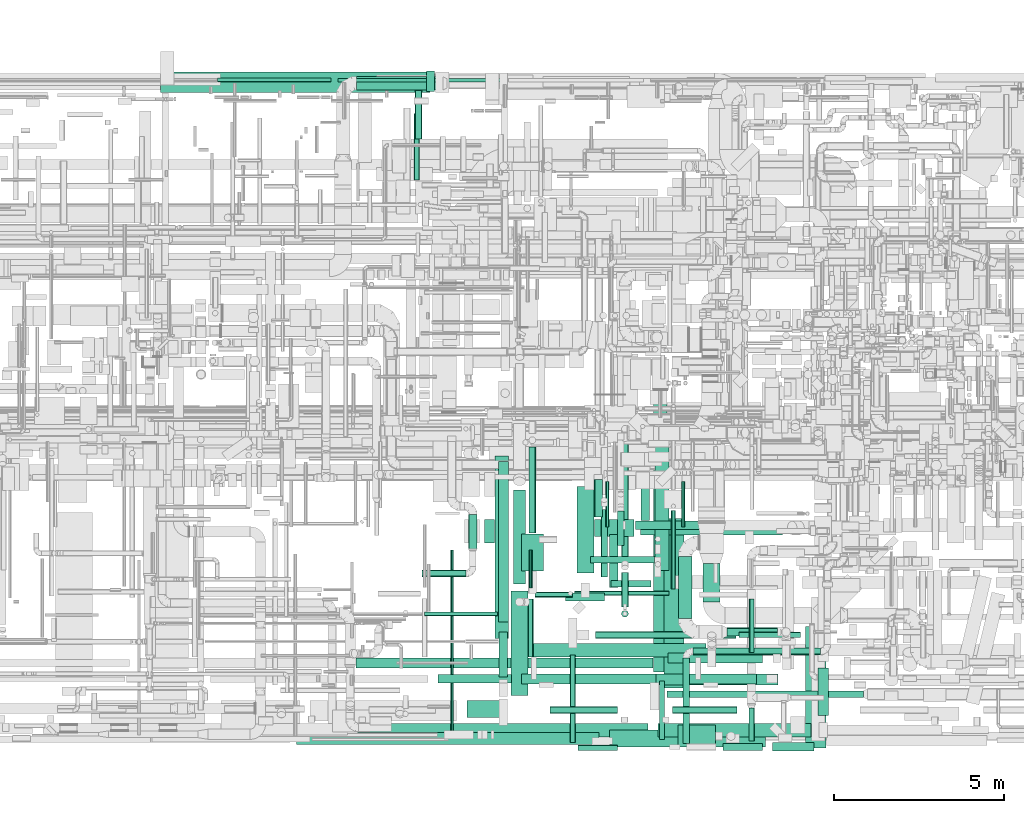
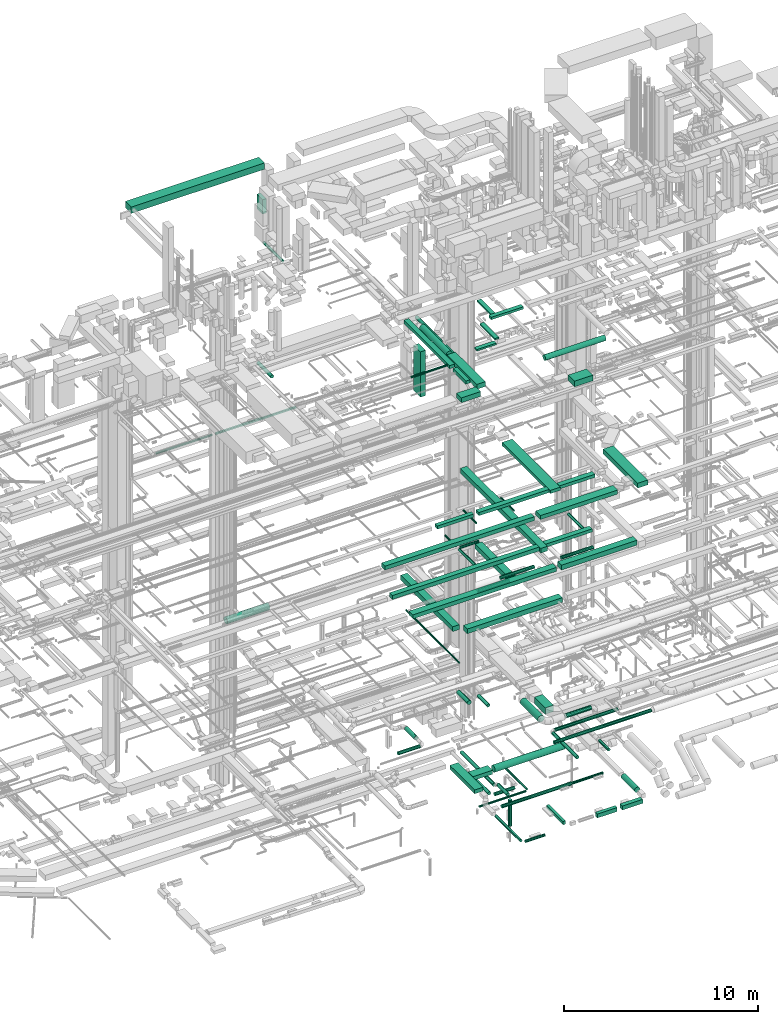
# One storey, part 37 of 337: 76 flow segments.
"""IFC2X3 building model written with IfcOpenShell, lengths in millimetres."""

from ifc_helpers import new_model, entity, si_unit, converted_unit, derived_unit, direction, frame, origin, origin_2d_with_axis, place, context, subcontext, project, spatial, rectangle, circle, extrude, type_object, element, save


model = new_model("IFC2X3")

# Units and contexts
model_context = context("Model", 3, precision=0.01, world=origin(), true_north=direction((6.12303176911189e-17, 1.0)))
body_context = subcontext(model_context, "Body", "Model", "MODEL_VIEW")
ifc_project = project(units=[si_unit("LENGTHUNIT", "METRE", prefix="MILLI"), si_unit("AREAUNIT", "SQUARE_METRE"), si_unit("VOLUMEUNIT", "CUBIC_METRE"), converted_unit("PLANEANGLEUNIT", "DEGREE", entity("IfcRatioMeasure", 0.0174532925199433), si_unit("PLANEANGLEUNIT", "RADIAN"), dimensions=[0, 0, 0, 0, 0, 0, 0]), si_unit("MASSUNIT", "GRAM", prefix="KILO"), derived_unit("MASSDENSITYUNIT", [(si_unit("MASSUNIT", "GRAM", prefix="KILO"), 1), (si_unit("LENGTHUNIT", "METRE"), -3)]), derived_unit("MOMENTOFINERTIAUNIT", [(si_unit("LENGTHUNIT", "METRE"), 4)]), si_unit("TIMEUNIT", "SECOND"), si_unit("FREQUENCYUNIT", "HERTZ"), si_unit("THERMODYNAMICTEMPERATUREUNIT", "DEGREE_CELSIUS"), derived_unit("THERMALTRANSMITTANCEUNIT", [(si_unit("MASSUNIT", "GRAM", prefix="KILO"), 1), (si_unit("THERMODYNAMICTEMPERATUREUNIT", "KELVIN"), -1), (si_unit("TIMEUNIT", "SECOND"), -3)]), derived_unit("VOLUMETRICFLOWRATEUNIT", [(si_unit("LENGTHUNIT", "METRE"), 3), (si_unit("TIMEUNIT", "SECOND"), -1)]), derived_unit("MASSFLOWRATEUNIT", [(si_unit("MASSUNIT", "GRAM", prefix="KILO"), 1), (si_unit("TIMEUNIT", "SECOND"), -1)]), derived_unit("ROTATIONALFREQUENCYUNIT", [(si_unit("TIMEUNIT", "SECOND"), -1)]), si_unit("ELECTRICCURRENTUNIT", "AMPERE"), si_unit("ELECTRICVOLTAGEUNIT", "VOLT"), si_unit("POWERUNIT", "WATT"), si_unit("FORCEUNIT", "NEWTON", prefix="KILO"), si_unit("ILLUMINANCEUNIT", "LUX"), si_unit("LUMINOUSFLUXUNIT", "LUMEN"), si_unit("LUMINOUSINTENSITYUNIT", "CANDELA"), derived_unit("USERDEFINED", [(si_unit("MASSUNIT", "GRAM", prefix="KILO"), -1), (si_unit("LENGTHUNIT", "METRE"), -2), (si_unit("TIMEUNIT", "SECOND"), 3), (si_unit("LUMINOUSFLUXUNIT", "LUMEN"), 1)]), derived_unit("LINEARVELOCITYUNIT", [(si_unit("LENGTHUNIT", "METRE"), 1), (si_unit("TIMEUNIT", "SECOND"), -1)]), si_unit("PRESSUREUNIT", "PASCAL"), derived_unit("USERDEFINED", [(si_unit("LENGTHUNIT", "METRE"), -2), (si_unit("MASSUNIT", "GRAM", prefix="KILO"), 1), (si_unit("TIMEUNIT", "SECOND"), -2)]), derived_unit("LINEARFORCEUNIT", [(si_unit("MASSUNIT", "GRAM", prefix="KILO"), 1), (si_unit("LENGTHUNIT", "METRE"), 1), (si_unit("TIMEUNIT", "SECOND"), -2), (si_unit("LENGTHUNIT", "METRE"), -1)]), derived_unit("PLANARFORCEUNIT", [(si_unit("MASSUNIT", "GRAM", prefix="KILO"), 1), (si_unit("LENGTHUNIT", "METRE"), 1), (si_unit("TIMEUNIT", "SECOND"), -2), (si_unit("LENGTHUNIT", "METRE"), -2)])], contexts=[model_context])

# Site, building, storey
site_placement = place(None, origin())
site = spatial("IfcSite", under=ifc_project, at=site_placement, CompositionType="ELEMENT")
building_placement = place(site_placement, origin())
building = spatial("IfcBuilding", under=site, at=building_placement, CompositionType="ELEMENT")
storey_placement = place(building_placement, origin())
storey = spatial("IfcBuildingStorey", under=building, at=storey_placement, CompositionType="ELEMENT", Elevation=0.0)

# Flow segments
duct_segment_type_1 = type_object("IfcDuctSegmentType", PredefinedType="NOTDEFINED")
flow_segment_1_placement = place(storey_placement, frame((42732.6, 6473.09, -975.0)))
element("IfcFlowSegment", 1, at=flow_segment_1_placement, inside=storey, type_object=duct_segment_type_1, context=body_context, shape_type="SweptSolid", body=[
    extrude(rectangle(XDim=1157.73140225018, YDim=500.0, at=origin_2d_with_axis()), frame((578.87, 250.0, 0.0), z_axis=(0.0, 0.0, 1.0), x_axis=(-1.0, 0.0, 0.0)), (0.0, 0.0, 1.0), 250.0),
])
flow_segment_2_placement = place(storey_placement, frame((47973.94, 148.87, -825.0)))
element("IfcFlowSegment", 2, at=flow_segment_2_placement, inside=storey, type_object=duct_segment_type_1, context=body_context, shape_type="SweptSolid", body=[
    extrude(rectangle(XDim=1214.65979800017, YDim=250.0, at=origin_2d_with_axis()), frame((607.33, 125.0, 0.0), z_axis=(0.0, 0.0, 1.0), x_axis=(-1.0, 0.0, 0.0)), (0.0, 0.0, 1.0), 250.0),
])
flow_segment_3_placement = place(storey_placement, frame((46506.13, 173.87, -825.0)))
element("IfcFlowSegment", 3, at=flow_segment_3_placement, inside=storey, type_object=duct_segment_type_1, context=body_context, shape_type="SweptSolid", body=[
    extrude(rectangle(XDim=1167.81204199994, YDim=200.0, at=origin_2d_with_axis()), frame((583.91, 100.0, 0.0), z_axis=(0.0, 0.0, 1.0), x_axis=(-1.0, 0.0, 0.0)), (0.0, 0.0, 1.0), 250.0),
])
flow_segment_4_placement = place(storey_placement, frame((44643.59, 498.87, -800.0)))
element("IfcFlowSegment", 4, at=flow_segment_4_placement, inside=storey, type_object=duct_segment_type_1, context=body_context, shape_type="SweptSolid", body=[
    extrude(rectangle(XDim=1718.27115999996, YDim=150.000000000001, at=origin_2d_with_axis()), frame((75.0, 859.14, 0.0), z_axis=(0.0, 0.0, 1.0), x_axis=(0.0, 1.0, 0.0)), (0.0, 0.0, 1.0), 200.0),
])
flow_segment_5_placement = place(storey_placement, frame((39796.81, 3472.88, 11250.0)))
element("IfcFlowSegment", 5, at=flow_segment_5_placement, inside=storey, type_object=duct_segment_type_1, context=body_context, shape_type="SweptSolid", body=[
    extrude(rectangle(XDim=5364.99999999978, YDim=400.000000000004, at=origin_2d_with_axis()), frame((200.0, 2682.5, 0.0), z_axis=(0.0, 0.0, 1.0), x_axis=(0.0, -1.0, 0.0)), (0.0, 0.0, 1.0), 300.000000000001),
])
flow_segment_6_placement = place(storey_placement, frame((40346.81, 2922.88, 11250.0)))
element("IfcFlowSegment", 6, at=flow_segment_6_placement, inside=storey, type_object=duct_segment_type_1, context=body_context, shape_type="SweptSolid", body=[
    extrude(rectangle(XDim=5665.00000000005, YDim=400.0, at=origin_2d_with_axis()), frame((2832.5, 200.0, 0.0)), (0.0, 0.0, 1.0), 300.000000000001),
])
flow_segment_7_placement = place(storey_placement, frame((44517.3, 5470.54, 11250.0)))
element("IfcFlowSegment", 7, at=flow_segment_7_placement, inside=storey, type_object=duct_segment_type_1, context=body_context, shape_type="SweptSolid", body=[
    extrude(rectangle(XDim=3870.00000000001, YDim=399.999999999996, at=origin_2d_with_axis()), frame((200.0, 1935.0, 0.0), z_axis=(0.0, 0.0, 1.0), x_axis=(0.0, -1.0, 0.0)), (0.0, 0.0, 1.0), 300.000000000001),
])
flow_segment_8_placement = place(storey_placement, frame((45925.84, 4546.24, 3250.0)))
element("IfcFlowSegment", 8, at=flow_segment_8_placement, inside=storey, type_object=duct_segment_type_1, context=body_context, shape_type="SweptSolid", body=[
    extrude(rectangle(XDim=1129.99999999995, YDim=499.999999999999, at=origin_2d_with_axis()), frame((250.0, 565.0, 0.0), z_axis=(0.0, 0.0, 1.0), x_axis=(0.0, 1.0, 0.0)), (0.0, 0.0, 1.0), 400.0),
])
flow_segment_9_placement = place(storey_placement, frame((35701.8, 2599.02, 15225.0)))
element("IfcFlowSegment", 9, at=flow_segment_9_placement, inside=storey, type_object=duct_segment_type_1, context=body_context, shape_type="SweptSolid", body=[
    extrude(rectangle(XDim=8747.07805931152, YDim=300.0, at=origin_2d_with_axis()), frame((4373.54, 150.0, 0.0)), (0.0, 0.0, 1.0), 249.999999999999),
])
flow_segment_10_placement = place(storey_placement, frame((44770.05, 2011.01, 19075.0)))
element("IfcFlowSegment", 10, at=flow_segment_10_placement, inside=storey, type_object=duct_segment_type_1, context=body_context, shape_type="SweptSolid", body=[
    extrude(rectangle(XDim=4988.50564939493, YDim=600.000000000002, at=origin_2d_with_axis()), frame((300.0, 2494.25, 0.0), z_axis=(0.0, 0.0, 1.0), x_axis=(0.0, 1.0, 0.0)), (0.0, 0.0, 1.0), 199.999999999998),
])
flow_segment_11_placement = place(storey_placement, frame((45390.05, 2127.06, 19075.0)))
element("IfcFlowSegment", 11, at=flow_segment_11_placement, inside=storey, type_object=duct_segment_type_1, context=body_context, shape_type="SweptSolid", body=[
    extrude(rectangle(XDim=2105.1724394272, YDim=300.0, at=origin_2d_with_axis()), frame((1052.59, 150.0, 0.0)), (0.0, 0.0, 1.0), 200.000000000002),
])
flow_segment_12_placement = place(storey_placement, frame((40585.22, 2126.32, 19075.0)))
element("IfcFlowSegment", 12, at=flow_segment_12_placement, inside=storey, type_object=duct_segment_type_1, context=body_context, shape_type="SweptSolid", body=[
    extrude(rectangle(XDim=4164.82756057291, YDim=300.0, at=origin_2d_with_axis()), frame((2082.41, 150.0, 0.0), z_axis=(0.0, 0.0, 1.0), x_axis=(-1.0, 0.0, 0.0)), (0.0, 0.0, 1.0), 200.000000000002),
])
flow_segment_13_placement = place(storey_placement, frame((38125.22, 2151.32, 19075.0)))
element("IfcFlowSegment", 13, at=flow_segment_13_placement, inside=storey, type_object=duct_segment_type_1, context=body_context, shape_type="SweptSolid", body=[
    extrude(rectangle(XDim=2160.0, YDim=250.0, at=origin_2d_with_axis()), frame((1080.0, 125.0, 0.0), z_axis=(0.0, 0.0, 1.0), x_axis=(-1.0, 0.0, 0.0)), (0.0, 0.0, 1.0), 199.999999999998),
])
flow_segment_14_placement = place(storey_placement, frame((48947.23, 249.41, 19025.0)))
element("IfcFlowSegment", 14, at=flow_segment_14_placement, inside=storey, type_object=duct_segment_type_1, context=body_context, shape_type="SweptSolid", body=[
    extrude(rectangle(XDim=3568.60389693213, YDim=600.000000000002, at=origin_2d_with_axis()), frame((300.0, 1784.3, 0.0), z_axis=(0.0, 0.0, 1.0), x_axis=(0.0, -1.0, 0.0)), (0.0, 0.0, 1.0), 300.000000000001),
])
flow_segment_15_placement = place(storey_placement, frame((33957.23, 350.82, 19050.0)))
element("IfcFlowSegment", 15, at=flow_segment_15_placement, inside=storey, type_object=duct_segment_type_1, context=body_context, shape_type="SweptSolid", body=[
    extrude(rectangle(XDim=8909.99999999995, YDim=350.0, at=origin_2d_with_axis()), frame((4455.0, 175.0, 0.0), z_axis=(0.0, 0.0, 1.0), x_axis=(-1.0, 0.0, 0.0)), (0.0, 0.0, 1.0), 249.999999999999),
])
flow_segment_16_placement = place(storey_placement, frame((35754.93, 570.66, 15225.0)))
element("IfcFlowSegment", 16, at=flow_segment_16_placement, inside=storey, type_object=duct_segment_type_1, context=body_context, shape_type="SweptSolid", body=[
    extrude(rectangle(XDim=8545.00000000031, YDim=400.0, at=origin_2d_with_axis()), frame((4272.5, 200.0, 0.0)), (0.0, 0.0, 1.0), 249.999999999999),
])
flow_segment_17_placement = place(storey_placement, frame((44468.87, 2481.34, 15150.0)))
element("IfcFlowSegment", 17, at=flow_segment_17_placement, inside=storey, type_object=duct_segment_type_1, context=body_context, shape_type="SweptSolid", body=[
    extrude(rectangle(XDim=8300.48692000003, YDim=399.999999999996, at=origin_2d_with_axis()), frame((200.0, 4150.24, 0.0), z_axis=(0.0, 0.0, 1.0), x_axis=(0.0, 1.0, 0.0)), (0.0, 0.0, 1.0), 300.000000000001),
])
flow_segment_18_placement = place(storey_placement, frame((44888.87, 2740.44, 15200.0)))
element("IfcFlowSegment", 18, at=flow_segment_18_placement, inside=storey, type_object=duct_segment_type_1, context=body_context, shape_type="SweptSolid", body=[
    extrude(rectangle(XDim=2792.13151510159, YDim=300.0, at=origin_2d_with_axis()), frame((1396.07, 150.0, 0.0), z_axis=(0.0, 0.0, 1.0), x_axis=(-1.0, 0.0, 0.0)), (0.0, 0.0, 1.0), 200.000000000002),
])
flow_segment_19_placement = place(storey_placement, frame((44599.93, 570.66, 15200.0)))
element("IfcFlowSegment", 19, at=flow_segment_19_placement, inside=storey, type_object=duct_segment_type_1, context=body_context, shape_type="SweptSolid", body=[
    extrude(rectangle(XDim=4499.36008441525, YDim=400.0, at=origin_2d_with_axis()), frame((2249.68, 200.0, 0.0)), (0.0, 0.0, 1.0), 300.000000000001),
])
flow_segment_20_placement = place(storey_placement, frame((35172.01, 19863.88, 15300.0)))
element("IfcFlowSegment", 20, at=flow_segment_20_placement, inside=storey, type_object=duct_segment_type_1, context=body_context, shape_type="SweptSolid", body=[
    extrude(rectangle(XDim=4780.0, YDim=99.9999999999989, at=origin_2d_with_axis()), frame((2390.0, 50.0, 0.0), z_axis=(0.0, 0.0, 1.0), x_axis=(-1.0, 0.0, 0.0)), (0.0, 0.0, 1.0), 99.9999999999989),
])
flow_segment_21_placement = place(storey_placement, frame((43167.23, 275.82, 19050.0)))
element("IfcFlowSegment", 21, at=flow_segment_21_placement, inside=storey, type_object=duct_segment_type_1, context=body_context, shape_type="SweptSolid", body=[
    extrude(rectangle(XDim=4600.31457505068, YDim=500.0, at=origin_2d_with_axis()), frame((2300.16, 250.0, 0.0)), (0.0, 0.0, 1.0), 249.999999999999),
])
flow_segment_22_placement = place(storey_placement, frame((39895.11, 3955.67, 27450.0)))
element("IfcFlowSegment", 22, at=flow_segment_22_placement, inside=storey, type_object=duct_segment_type_1, context=body_context, shape_type="SweptSolid", body=[
    extrude(rectangle(XDim=4724.30225818221, YDim=300.000000000001, at=origin_2d_with_axis()), frame((150.0, 2362.15, 0.0), z_axis=(0.0, 0.0, 1.0), x_axis=(0.0, 1.0, 0.0)), (0.0, 0.0, 1.0), 199.999999999998),
])
flow_segment_23_placement = place(storey_placement, frame((43940.82, 6674.99, 27475.0)))
element("IfcFlowSegment", 23, at=flow_segment_23_placement, inside=storey, type_object=duct_segment_type_1, context=body_context, shape_type="SweptSolid", body=[
    extrude(rectangle(XDim=1920.00000000001, YDim=250.000000000001, at=origin_2d_with_axis()), frame((960.0, 125.0, 0.0), z_axis=(0.0, 0.0, 1.0), x_axis=(-1.0, 0.0, 0.0)), (0.0, 0.0, 1.0), 150.000000000001),
])
flow_segment_24_placement = place(storey_placement, frame((43170.82, 4965.79, 27500.0)))
element("IfcFlowSegment", 24, at=flow_segment_24_placement, inside=storey, type_object=duct_segment_type_1, context=body_context, shape_type="SweptSolid", body=[
    extrude(rectangle(XDim=1559.20000000447, YDim=250.000000000004, at=origin_2d_with_axis()), frame((125.0, 779.6, 0.0), z_axis=(0.0, 0.0, 1.0), x_axis=(0.0, -1.0, 0.0)), (0.0, 0.0, 1.0), 100.000000000003),
])
flow_segment_25_placement = place(storey_placement, frame((41870.0, 4565.79, 27500.0)))
element("IfcFlowSegment", 25, at=flow_segment_25_placement, inside=storey, type_object=duct_segment_type_1, context=body_context, shape_type="SweptSolid", body=[
    extrude(rectangle(XDim=1150.81901357669, YDim=250.0, at=origin_2d_with_axis()), frame((575.41, 125.0, 0.0), z_axis=(0.0, 0.0, 1.0), x_axis=(-1.0, 0.0, 0.0)), (0.0, 0.0, 1.0), 100.000000000003),
])
flow_segment_26_placement = place(storey_placement, frame((44092.26, 6944.99, 27500.0)))
element("IfcFlowSegment", 26, at=flow_segment_26_placement, inside=storey, type_object=duct_segment_type_1, context=body_context, shape_type="SweptSolid", body=[
    extrude(rectangle(XDim=1460.79999999618, YDim=250.000000000004, at=origin_2d_with_axis()), frame((125.0, 730.4, 0.0), z_axis=(0.0, 0.0, 1.0), x_axis=(0.0, 1.0, 0.0)), (0.0, 0.0, 1.0), 100.000000000003),
])
flow_segment_27_placement = place(storey_placement, frame((37785.11, 19579.6, 28445.0)))
element("IfcFlowSegment", 27, at=flow_segment_27_placement, inside=storey, type_object=duct_segment_type_1, context=body_context, shape_type="SweptSolid", body=[
    extrude(rectangle(XDim=234.996671260808, YDim=600.000000000002, at=origin_2d_with_axis()), frame((117.5, 300.0, 0.0), z_axis=(0.0, 0.0, 1.0), x_axis=(-1.0, 0.0, 0.0)), (0.0, 0.0, 1.0), 900.000000000003),
])
flow_segment_28_placement = place(storey_placement, frame((29949.08, 19554.6, 31250.05)))
element("IfcFlowSegment", 28, at=flow_segment_28_placement, inside=storey, type_object=duct_segment_type_1, context=body_context, shape_type="SweptSolid", body=[
    extrude(rectangle(XDim=7941.0298276989, YDim=599.999999999998, at=origin_2d_with_axis()), frame((3970.51, 300.0, 0.0)), (0.0, 0.0, 1.0), 399.999999999996),
])
flow_segment_29_placement = place(storey_placement, frame((38970.0, 1144.06, 27350.0)))
element("IfcFlowSegment", 29, at=flow_segment_29_placement, inside=storey, type_object=duct_segment_type_1, context=body_context, shape_type="SweptSolid", body=[
    extrude(rectangle(XDim=1150.62499999995, YDim=500.0, at=origin_2d_with_axis()), frame((575.31, 250.0, 0.0), z_axis=(0.0, 0.0, 1.0), x_axis=(-1.0, 0.0, 0.0)), (0.0, 0.0, 1.0), 300.000000000001),
])
flow_segment_30_placement = place(storey_placement, frame((40270.63, 1794.06, 27350.0)))
element("IfcFlowSegment", 30, at=flow_segment_30_placement, inside=storey, type_object=duct_segment_type_1, context=body_context, shape_type="SweptSolid", body=[
    extrude(rectangle(XDim=3080.00000000001, YDim=499.999999999999, at=origin_2d_with_axis()), frame((250.0, 1540.0, 0.0), z_axis=(0.0, 0.0, 1.0), x_axis=(0.0, 1.0, 0.0)), (0.0, 0.0, 1.0), 300.000000000001),
])
flow_segment_31_placement = place(storey_placement, frame((39490.62, 6277.81, 24400.0)))
element("IfcFlowSegment", 31, at=flow_segment_31_placement, inside=storey, type_object=duct_segment_type_1, context=body_context, shape_type="SweptSolid", body=[
    extrude(rectangle(XDim=699.999999999999, YDim=300.000000000001, at=origin_2d_with_axis()), frame((150.0, 350.0, 0.0), z_axis=(0.0, 0.0, 1.0), x_axis=(0.0, 1.0, 0.0)), (0.0, 0.0, 1.0), 2849.99999999998),
])
flow_segment_32_placement = place(storey_placement, frame((42212.6, 5397.31, -975.0)))
element("IfcFlowSegment", 32, at=flow_segment_32_placement, inside=storey, type_object=duct_segment_type_1, context=body_context, shape_type="SweptSolid", body=[
    extrude(rectangle(XDim=2552.57800957389, YDim=499.999999999999, at=origin_2d_with_axis()), frame((250.0, 1276.29, 0.0), z_axis=(0.0, 0.0, 1.0), x_axis=(0.0, -1.0, 0.0)), (0.0, 0.0, 1.0), 250.0),
])
flow_segment_33_placement = place(storey_placement, frame((40576.66, 5449.21, 26600.0)))
element("IfcFlowSegment", 33, at=flow_segment_33_placement, inside=storey, type_object=duct_segment_type_1, context=body_context, shape_type="SweptSolid", body=[
    extrude(rectangle(XDim=1100.0, YDim=650.0, at=origin_2d_with_axis()), frame((325.0, 550.0, 0.0), z_axis=(0.0, 0.0, 1.0), x_axis=(0.0, -1.0, 0.0)), (0.0, 0.0, 1.0), 349.999999999998),
])
flow_segment_34_placement = place(storey_placement, frame((45194.8, 268.17, 26700.0)))
element("IfcFlowSegment", 34, at=flow_segment_34_placement, inside=storey, type_object=duct_segment_type_1, context=body_context, shape_type="SweptSolid", body=[
    extrude(rectangle(XDim=1100.0, YDim=650.0, at=origin_2d_with_axis()), frame((550.0, 325.0, 0.0)), (0.0, 0.0, 1.0), 349.999999999998),
])
flow_segment_35_placement = place(storey_placement, frame((39920.11, 2335.66, 27450.0)))
element("IfcFlowSegment", 35, at=flow_segment_35_placement, inside=storey, type_object=duct_segment_type_1, context=body_context, shape_type="SweptSolid", body=[
    extrude(rectangle(XDim=1320.01270374874, YDim=250.000000000004, at=origin_2d_with_axis()), frame((125.0, 660.01, 0.0), z_axis=(0.0, 0.0, 1.0), x_axis=(0.0, -1.0, 0.0)), (0.0, 0.0, 1.0), 199.999999999998),
])
duct_segment_type_2 = type_object("IfcDuctSegmentType", PredefinedType="NOTDEFINED")
flow_segment_36_placement = place(storey_placement, frame((42008.0, 408.86, -931.6)))
element("IfcFlowSegment", 36, at=flow_segment_36_placement, inside=storey, type_object=duct_segment_type_2, context=body_context, shape_type="SweptSolid", body=[
    extrude(circle(Radius=80.0, at=origin_2d_with_axis()), frame((81.6, 0.0, 81.6), z_axis=(0.0, 1.0, 0.0), x_axis=(-1.0, 0.0, 0.0)), (0.0, 0.0, 1.0), 2573.12127075),
])
flow_segment_37_placement = place(storey_placement, frame((42249.6, 167.27, -931.6)))
element("IfcFlowSegment", 37, at=flow_segment_37_placement, inside=storey, type_object=duct_segment_type_2, context=body_context, shape_type="SweptSolid", body=[
    extrude(circle(Radius=80.0, at=origin_2d_with_axis()), frame((0.0, 81.6, 81.6), z_axis=(1.0, 0.0, 0.0), x_axis=(0.0, -1.0, 0.0)), (0.0, 0.0, 1.0), 1160.00000000006),
])
flow_segment_38_placement = place(storey_placement, frame((46979.14, 3491.94, -931.6)))
element("IfcFlowSegment", 38, at=flow_segment_38_placement, inside=storey, type_object=duct_segment_type_2, context=body_context, shape_type="SweptSolid", body=[
    extrude(circle(Radius=80.0, at=origin_2d_with_axis()), frame((0.0, 81.6, 81.6), z_axis=(1.0, 0.0, 0.0), x_axis=(0.0, -1.0, 0.0)), (0.0, 0.0, 1.0), 1819.13111635832),
])
flow_segment_39_placement = place(storey_placement, frame((42764.91, 3471.94, -951.6)))
element("IfcFlowSegment", 39, at=flow_segment_39_placement, inside=storey, type_object=duct_segment_type_2, context=body_context, shape_type="SweptSolid", body=[
    extrude(circle(Radius=100.0, at=origin_2d_with_axis()), frame((0.0, 101.6, 101.6), z_axis=(1.0, 0.0, 0.0), x_axis=(0.0, -1.0, 0.0)), (0.0, 0.0, 1.0), 4129.2321745),
])
flow_segment_40_placement = place(storey_placement, frame((49304.5, 1195.38, -859.1)))
element("IfcFlowSegment", 40, at=flow_segment_40_placement, inside=storey, type_object=duct_segment_type_2, context=body_context, shape_type="SweptSolid", body=[
    extrude(circle(Radius=157.5, at=origin_2d_with_axis()), frame((159.1, 0.0, 159.1), z_axis=(0.0, 1.0, 0.0), x_axis=(-1.0, 0.0, 0.0)), (0.0, 0.0, 1.0), 1400.38555541775),
])
flow_segment_41_placement = place(storey_placement, frame((43524.07, 4096.72, -2732.5)))
element("IfcFlowSegment", 41, at=flow_segment_41_placement, inside=storey, type_object=duct_segment_type_2, context=body_context, shape_type="SweptSolid", body=[
    extrude(circle(Radius=100.0, at=origin_2d_with_axis()), frame((101.6, 101.6, 0.0)), (0.0, 0.0, 1.0), 1632.49996525),
])
flow_segment_42_placement = place(storey_placement, frame((42140.31, 4734.54, -1444.1)))
element("IfcFlowSegment", 42, at=flow_segment_42_placement, inside=storey, type_object=duct_segment_type_2, context=body_context, shape_type="SweptSolid", body=[
    extrude(circle(Radius=62.5, at=origin_2d_with_axis()), frame((0.0, 64.1, 64.1), z_axis=(1.0, 0.0, 0.0), x_axis=(0.0, -1.0, 0.0)), (0.0, 0.0, 1.0), 2785.16149000003),
])
flow_segment_43_placement = place(storey_placement, frame((43212.65, 4977.17, -1251.6)))
element("IfcFlowSegment", 43, at=flow_segment_43_placement, inside=storey, type_object=duct_segment_type_2, context=body_context, shape_type="SweptSolid", body=[
    extrude(circle(Radius=100.0, at=origin_2d_with_axis()), frame((0.0, 101.6, 101.6), z_axis=(1.0, 0.0, 0.0), x_axis=(0.0, -1.0, 0.0)), (0.0, 0.0, 1.0), 1181.39538000001),
])
flow_segment_44_placement = place(storey_placement, frame((38481.17, 600.02, 11418.4)))
element("IfcFlowSegment", 44, at=flow_segment_44_placement, inside=storey, type_object=duct_segment_type_2, context=body_context, shape_type="SweptSolid", body=[
    extrude(circle(Radius=50.0, at=origin_2d_with_axis()), frame((51.6, 0.0, 51.6), z_axis=(0.0, 1.0, 0.0), x_axis=(1.0, 0.0, 0.0)), (0.0, 0.0, 1.0), 5477.86105600285),
])
flow_segment_45_placement = place(storey_placement, frame((42617.3, 5688.3, 11298.4)))
element("IfcFlowSegment", 45, at=flow_segment_45_placement, inside=storey, type_object=duct_segment_type_2, context=body_context, shape_type="SweptSolid", body=[
    extrude(circle(Radius=100.0, at=origin_2d_with_axis()), frame((0.0, 101.6, 101.6), z_axis=(1.0, 0.0, 0.0), x_axis=(0.0, 1.0, 0.0)), (0.0, 0.0, 1.0), 1879.99999999997),
])
flow_segment_46_placement = place(storey_placement, frame((35722.98, 19617.8, 3268.4)))
element("IfcFlowSegment", 46, at=flow_segment_46_placement, inside=storey, type_object=duct_segment_type_2, context=body_context, shape_type="SweptSolid", body=[
    extrude(circle(Radius=200.0, at=origin_2d_with_axis()), frame((0.0, 201.6, 201.6), z_axis=(1.0, 0.0, 0.0), x_axis=(0.0, -1.0, 0.0)), (0.0, 0.0, 1.0), 2536.875),
])
flow_segment_47_placement = place(storey_placement, frame((39017.55, 6105.04, 3053.4)))
element("IfcFlowSegment", 47, at=flow_segment_47_placement, inside=storey, type_object=duct_segment_type_2, context=body_context, shape_type="SweptSolid", body=[
    extrude(circle(Radius=125.0, at=origin_2d_with_axis()), frame((126.6, 0.0, 126.6), z_axis=(0.0, 1.0, 0.0), x_axis=(-1.0, 0.0, 0.0)), (0.0, 0.0, 1.0), 1009.99999999999),
])
flow_segment_48_placement = place(storey_placement, frame((37644.14, 5283.45, 3078.4)))
element("IfcFlowSegment", 48, at=flow_segment_48_placement, inside=storey, type_object=duct_segment_type_2, context=body_context, shape_type="SweptSolid", body=[
    extrude(circle(Radius=100.0, at=origin_2d_with_axis()), frame((0.0, 101.6, 101.6), z_axis=(1.0, 0.0, 0.0), x_axis=(0.0, 1.0, 0.0)), (0.0, 0.0, 1.0), 1299.99999999999),
])
flow_segment_49_placement = place(storey_placement, frame((37444.16, 18175.32, 19068.4)))
element("IfcFlowSegment", 49, at=flow_segment_49_placement, inside=storey, type_object=duct_segment_type_2, context=body_context, shape_type="SweptSolid", body=[
    extrude(circle(Radius=100.0, at=origin_2d_with_axis()), frame((101.6, 0.0, 101.6), z_axis=(0.0, 1.0, 0.0), x_axis=(-1.0, 0.0, 0.0)), (0.0, 0.0, 1.0), 1429.99999999996),
])
flow_segment_50_placement = place(storey_placement, frame((41412.2, 1260.8, 15248.4)))
element("IfcFlowSegment", 50, at=flow_segment_50_placement, inside=storey, type_object=duct_segment_type_2, context=body_context, shape_type="SweptSolid", body=[
    extrude(circle(Radius=100.0, at=origin_2d_with_axis()), frame((0.0, 101.6, 101.6), z_axis=(1.0, 0.0, 0.0), x_axis=(0.0, 1.0, 0.0)), (0.0, 0.0, 1.0), 2000.00000000001),
])
flow_segment_51_placement = place(storey_placement, frame((45027.95, 1260.8, 15248.4)))
element("IfcFlowSegment", 51, at=flow_segment_51_placement, inside=storey, type_object=duct_segment_type_2, context=body_context, shape_type="SweptSolid", body=[
    extrude(circle(Radius=100.0, at=origin_2d_with_axis()), frame((0.0, 101.6, 101.6), z_axis=(1.0, 0.0, 0.0), x_axis=(0.0, -1.0, 0.0)), (0.0, 0.0, 1.0), 1899.99999999999),
])
flow_segment_52_placement = place(storey_placement, frame((40769.88, 2919.02, 15268.4)))
element("IfcFlowSegment", 52, at=flow_segment_52_placement, inside=storey, type_object=duct_segment_type_2, context=body_context, shape_type="SweptSolid", body=[
    extrude(circle(Radius=80.0, at=origin_2d_with_axis()), frame((81.6, 0.0, 81.6), z_axis=(0.0, 1.0, 0.0), x_axis=(-1.0, 0.0, 0.0)), (0.0, 0.0, 1.0), 1713.06945623724),
])
flow_segment_53_placement = place(storey_placement, frame((40799.88, 4952.09, 15298.4)))
element("IfcFlowSegment", 53, at=flow_segment_53_placement, inside=storey, type_object=duct_segment_type_2, context=body_context, shape_type="SweptSolid", body=[
    extrude(circle(Radius=50.0, at=origin_2d_with_axis()), frame((51.6, 0.0, 51.6), z_axis=(0.0, 1.0, 0.0), x_axis=(1.0, 0.0, 0.0)), (0.0, 0.0, 1.0), 1120.0),
])
flow_segment_54_placement = place(storey_placement, frame((40981.47, 4680.5, 15268.4)))
element("IfcFlowSegment", 54, at=flow_segment_54_placement, inside=storey, type_object=duct_segment_type_2, context=body_context, shape_type="SweptSolid", body=[
    extrude(circle(Radius=80.0, at=origin_2d_with_axis()), frame((0.0, 81.6, 81.6), z_axis=(1.0, 0.0, 0.0), x_axis=(0.0, -1.0, 0.0)), (0.0, 0.0, 1.0), 1100.0),
])
flow_segment_55_placement = place(storey_placement, frame((47271.0, 3060.44, 15218.4)))
element("IfcFlowSegment", 55, at=flow_segment_55_placement, inside=storey, type_object=duct_segment_type_2, context=body_context, shape_type="SweptSolid", body=[
    extrude(circle(Radius=80.0, at=origin_2d_with_axis()), frame((81.6, 0.0, 81.6), z_axis=(0.0, 1.0, 0.0), x_axis=(-1.0, 0.0, 0.0)), (0.0, 0.0, 1.0), 1571.64809999993),
])
flow_segment_56_placement = place(storey_placement, frame((45288.83, 6759.63, 14868.4)))
element("IfcFlowSegment", 56, at=flow_segment_56_placement, inside=storey, type_object=duct_segment_type_2, context=body_context, shape_type="SweptSolid", body=[
    extrude(circle(Radius=50.0, at=origin_2d_with_axis()), frame((51.6, 0.0, 51.6), z_axis=(0.0, 1.0, 0.0), x_axis=(-1.0, 0.0, 0.0)), (0.0, 0.0, 1.0), 1340.0000000001),
])
flow_segment_57_placement = place(storey_placement, frame((43054.81, 6759.63, 14868.4)))
element("IfcFlowSegment", 57, at=flow_segment_57_placement, inside=storey, type_object=duct_segment_type_2, context=body_context, shape_type="SweptSolid", body=[
    extrude(circle(Radius=50.0, at=origin_2d_with_axis()), frame((51.6, 0.0, 51.6), z_axis=(0.0, 1.0, 0.0), x_axis=(-1.0, 0.0, 0.0)), (0.0, 0.0, 1.0), 1340.00000000008),
])
flow_segment_58_placement = place(storey_placement, frame((31632.01, 19849.79, 15285.9)))
element("IfcFlowSegment", 58, at=flow_segment_58_placement, inside=storey, type_object=duct_segment_type_2, context=body_context, shape_type="SweptSolid", body=[
    extrude(circle(Radius=62.5, at=origin_2d_with_axis()), frame((0.0, 64.1, 64.1), z_axis=(1.0, 0.0, 0.0), x_axis=(0.0, 1.0, 0.0)), (0.0, 0.0, 1.0), 3340.0),
])
flow_segment_59_placement = place(storey_placement, frame((44544.15, 2100.95, 27390.9)))
element("IfcFlowSegment", 59, at=flow_segment_59_placement, inside=storey, type_object=duct_segment_type_2, context=body_context, shape_type="SweptSolid", body=[
    extrude(circle(Radius=157.5, at=origin_2d_with_axis()), frame((0.0, 159.1, 159.1), z_axis=(1.0, 0.0, 0.0), x_axis=(0.0, 1.0, 0.0)), (0.0, 0.0, 1.0), 3589.99999999997),
])
flow_segment_60_placement = place(storey_placement, frame((37410.61, 16976.34, 27088.4)))
element("IfcFlowSegment", 60, at=flow_segment_60_placement, inside=storey, type_object=duct_segment_type_2, context=body_context, shape_type="SweptSolid", body=[
    extrude(circle(Radius=80.0, at=origin_2d_with_axis()), frame((81.6, 0.0, 81.6), z_axis=(0.0, 1.0, 0.0), x_axis=(1.0, 0.0, 0.0)), (0.0, 0.0, 1.0), 1949.99999999999),
])
flow_segment_61_placement = place(storey_placement, frame((37725.98, 4123.11, 27485.9)))
element("IfcFlowSegment", 61, at=flow_segment_61_placement, inside=storey, type_object=duct_segment_type_2, context=body_context, shape_type="SweptSolid", body=[
    extrude(circle(Radius=62.5, at=origin_2d_with_axis()), frame((0.0, 64.1, 64.1), z_axis=(1.0, 0.0, 0.0), x_axis=(0.0, 1.0, 0.0)), (0.0, 0.0, 1.0), 2149.13004046769),
])
flow_segment_62_placement = place(storey_placement, frame((42718.02, 7044.11, 3423.4)))
element("IfcFlowSegment", 62, at=flow_segment_62_placement, inside=storey, type_object=duct_segment_type_2, context=body_context, shape_type="SweptSolid", body=[
    extrude(circle(Radius=125.0, at=origin_2d_with_axis()), frame((126.6, 0.0, 126.6), z_axis=(0.0, 1.0, 0.0), x_axis=(-1.0, 0.0, 0.0)), (0.0, 0.0, 1.0), 1108.39999999998),
])
flow_segment_63_placement = place(storey_placement, frame((43401.76, 6207.79, 3538.4)))
element("IfcFlowSegment", 63, at=flow_segment_63_placement, inside=storey, type_object=duct_segment_type_2, context=body_context, shape_type="SweptSolid", body=[
    extrude(circle(Radius=100.0, at=origin_2d_with_axis()), frame((101.6, 0.0, 101.6), z_axis=(0.0, 1.0, 0.0), x_axis=(-1.0, 0.0, 0.0)), (0.0, 0.0, 1.0), 1017.15728752539),
])
flow_segment_64_placement = place(storey_placement, frame((45198.25, 4061.24, 3248.4)))
element("IfcFlowSegment", 64, at=flow_segment_64_placement, inside=storey, type_object=duct_segment_type_2, context=body_context, shape_type="SweptSolid", body=[
    extrude(circle(Radius=200.0, at=origin_2d_with_axis()), frame((201.6, 0.0, 201.6), z_axis=(0.0, 1.0, 0.0), x_axis=(-1.0, 0.0, 0.0)), (0.0, 0.0, 1.0), 1820.00000000004),
])
flow_segment_65_placement = place(storey_placement, frame((46629.84, 3534.65, 3323.4)))
element("IfcFlowSegment", 65, at=flow_segment_65_placement, inside=storey, type_object=duct_segment_type_2, context=body_context, shape_type="SweptSolid", body=[
    extrude(circle(Radius=125.0, at=origin_2d_with_axis()), frame((0.0, 126.6, 126.6), z_axis=(1.0, 0.0, 0.0), x_axis=(0.0, -1.0, 0.0)), (0.0, 0.0, 1.0), 1489.99999999999),
])
flow_segment_66_placement = place(storey_placement, frame((40797.44, 6581.51, 27138.4)))
element("IfcFlowSegment", 66, at=flow_segment_66_placement, inside=storey, type_object=duct_segment_type_2, context=body_context, shape_type="SweptSolid", body=[
    extrude(circle(Radius=100.0, at=origin_2d_with_axis()), frame((101.6, 0.0, 101.6), z_axis=(0.0, 1.0, 0.0), x_axis=(1.0, 0.0, 0.0)), (0.0, 0.0, 1.0), 2526.89520253552),
])
flow_segment_67_placement = place(storey_placement, frame((44090.33, 6521.49, -1051.6)))
element("IfcFlowSegment", 67, at=flow_segment_67_placement, inside=storey, type_object=duct_segment_type_2, context=body_context, shape_type="SweptSolid", body=[
    extrude(circle(Radius=200.0, at=origin_2d_with_axis()), frame((0.0, 201.6, 201.6), z_axis=(1.0, 0.0, 0.0), x_axis=(0.0, -1.0, 0.0)), (0.0, 0.0, 1.0), 4176.36310262494),
])
flow_segment_68_placement = place(storey_placement, frame((44986.38, 4923.63, -1444.1)))
element("IfcFlowSegment", 68, at=flow_segment_68_placement, inside=storey, type_object=duct_segment_type_2, context=body_context, shape_type="SweptSolid", body=[
    extrude(circle(Radius=62.5, at=origin_2d_with_axis()), frame((64.1, 0.0, 64.1), z_axis=(0.0, 1.0, 0.0), x_axis=(-1.0, 0.0, 0.0)), (0.0, 0.0, 1.0), 2316.81008000003),
])
flow_segment_69_placement = place(storey_placement, frame((45629.84, 2987.52, 3148.4)))
element("IfcFlowSegment", 69, at=flow_segment_69_placement, inside=storey, type_object=duct_segment_type_2, context=body_context, shape_type="SweptSolid", body=[
    extrude(circle(Radius=100.0, at=origin_2d_with_axis()), frame((0.0, 101.6, 101.6), z_axis=(1.0, 0.0, 0.0), x_axis=(0.0, -1.0, 0.0)), (0.0, 0.0, 1.0), 3750.15892086963),
])
flow_segment_70_placement = place(storey_placement, frame((45328.25, 369.11, 3148.4)))
element("IfcFlowSegment", 70, at=flow_segment_70_placement, inside=storey, type_object=duct_segment_type_2, context=body_context, shape_type="SweptSolid", body=[
    extrude(circle(Radius=100.0, at=origin_2d_with_axis()), frame((101.6, 0.0, 101.6), z_axis=(0.0, 1.0, 0.0), x_axis=(-1.0, 0.0, 0.0)), (0.0, 0.0, 1.0), 2519.99999999999),
])
flow_segment_71_placement = place(storey_placement, frame((47272.3, 447.79, 2918.4)))
element("IfcFlowSegment", 71, at=flow_segment_71_placement, inside=storey, type_object=duct_segment_type_2, context=body_context, shape_type="SweptSolid", body=[
    extrude(circle(Radius=80.0, at=origin_2d_with_axis()), frame((81.6, 0.0, 81.6), z_axis=(0.0, 1.0, 0.0), x_axis=(-1.0, 0.0, 0.0)), (0.0, 0.0, 1.0), 974.800281599996),
])
flow_segment_72_placement = place(storey_placement, frame((40341.53, 5074.06, 27320.9)))
element("IfcFlowSegment", 72, at=flow_segment_72_placement, inside=storey, type_object=duct_segment_type_2, context=body_context, shape_type="SweptSolid", body=[
    extrude(circle(Radius=177.5, at=origin_2d_with_axis()), frame((179.1, 0.0, 179.1), z_axis=(0.0, 1.0, 0.0), x_axis=(1.0, 0.0, 0.0)), (0.0, 0.0, 1.0), 2770.70418743221),
])
flow_segment_73_placement = place(storey_placement, frame((44863.55, 1727.77, 3398.4)))
element("IfcFlowSegment", 73, at=flow_segment_73_placement, inside=storey, type_object=duct_segment_type_2, context=body_context, shape_type="SweptSolid", body=[
    extrude(circle(Radius=100.0, at=origin_2d_with_axis()), frame((0.0, 101.6, 101.6), z_axis=(1.0, 0.0, 0.0), x_axis=(0.0, 1.0, 0.0)), (0.0, 0.0, 1.0), 5784.99999999999),
])
flow_segment_74_placement = place(storey_placement, frame((43524.07, 5830.56, -1251.6)))
element("IfcFlowSegment", 74, at=flow_segment_74_placement, inside=storey, type_object=duct_segment_type_2, context=body_context, shape_type="SweptSolid", body=[
    extrude(circle(Radius=100.0, at=origin_2d_with_axis()), frame((101.6, 0.0, 101.6), z_axis=(0.0, 1.0, 0.0), x_axis=(-1.0, 0.0, 0.0)), (0.0, 0.0, 1.0), 3363.38247274451),
])
flow_segment_75_placement = place(storey_placement, frame((43524.07, 4398.32, -1001.6)))
element("IfcFlowSegment", 75, at=flow_segment_75_placement, inside=storey, type_object=duct_segment_type_2, context=body_context, shape_type="SweptSolid", body=[
    extrude(circle(Radius=100.0, at=origin_2d_with_axis()), frame((101.6, 0.0, 101.6), z_axis=(0.0, 1.0, 0.0), x_axis=(1.0, 0.0, 0.0)), (0.0, 0.0, 1.0), 1016.55439752541),
])
flow_segment_76_placement = place(storey_placement, frame((42911.05, 5278.77, -1251.6)))
element("IfcFlowSegment", 76, at=flow_segment_76_placement, inside=storey, type_object=duct_segment_type_2, context=body_context, shape_type="SweptSolid", body=[
    extrude(circle(Radius=100.0, at=origin_2d_with_axis()), frame((101.6, 0.0, 101.6), z_axis=(0.0, 1.0, 0.0), x_axis=(1.0, 0.0, 0.0)), (0.0, 0.0, 1.0), 1994.11404829608),
])

save(model, "model.ifc")
